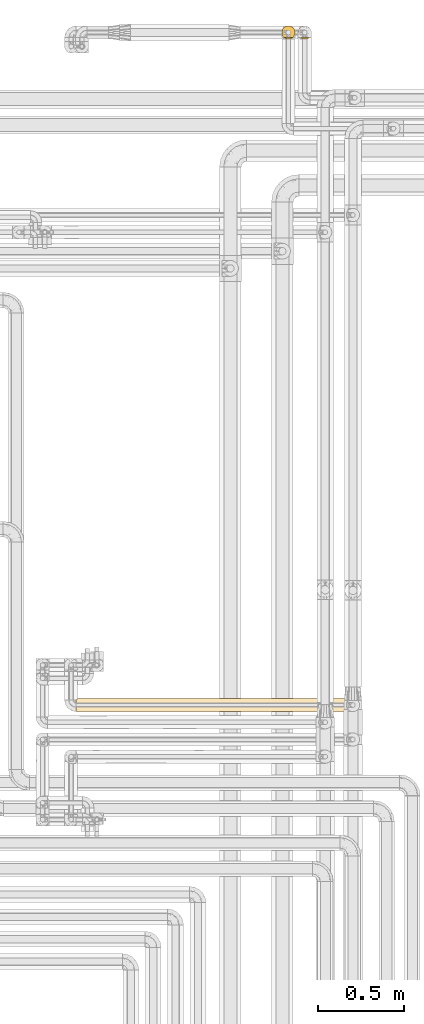
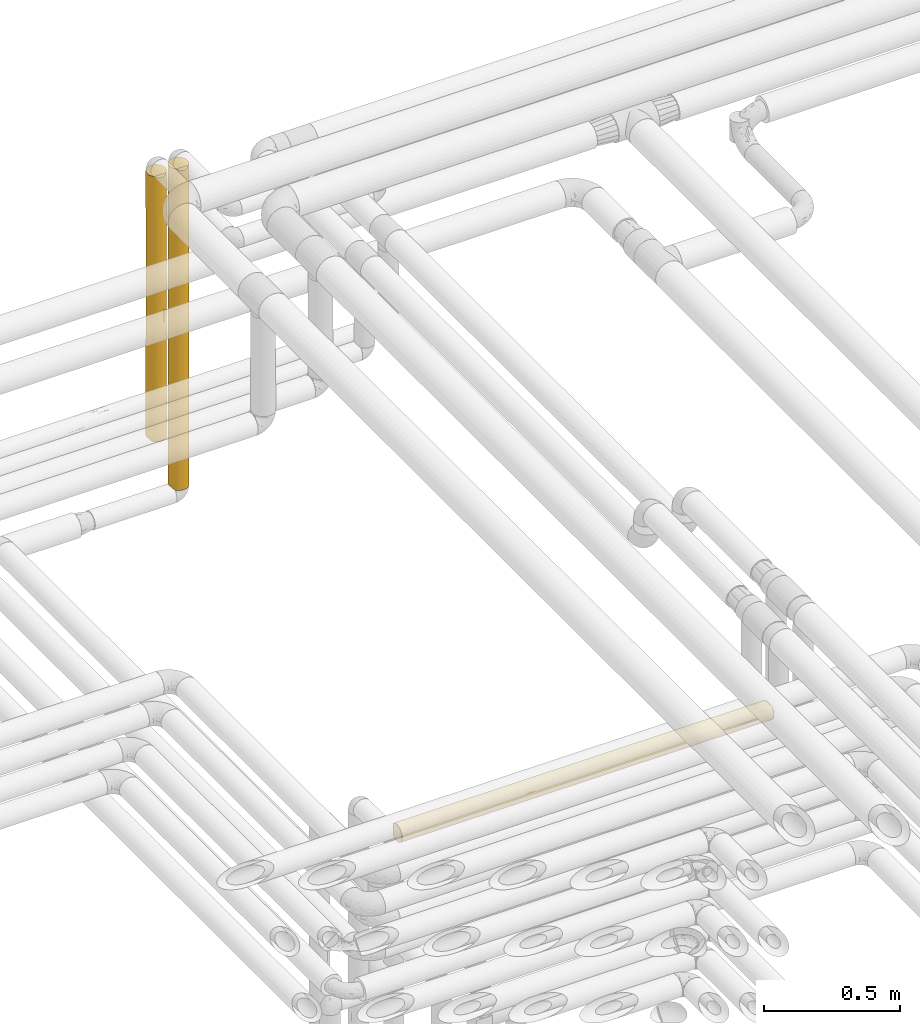
# One storey, part 44 of 827: 3 coverings.
"""IFC2X3 building model written with IfcOpenShell, lengths in millimetres."""

from ifc_helpers import new_model, entity, si_unit, converted_unit, derived_unit, direction, frame, origin, place, context, subcontext, project, spatial, faceted_brep, element, save


model = new_model("IFC2X3")

# Units and contexts
model_context = context("Model", 3, precision=0.01, world=origin(), true_north=direction((6.12303176911189e-17, 1.0)))
body_context = subcontext(model_context, "Body", "Model", "MODEL_VIEW")
ifc_project = project(units=[si_unit("LENGTHUNIT", "METRE", prefix="MILLI"), si_unit("AREAUNIT", "SQUARE_METRE"), si_unit("VOLUMEUNIT", "CUBIC_METRE"), converted_unit("PLANEANGLEUNIT", "DEGREE", entity("IfcRatioMeasure", 0.0174532925199433), si_unit("PLANEANGLEUNIT", "RADIAN"), dimensions=[0, 0, 0, 0, 0, 0, 0]), si_unit("MASSUNIT", "GRAM", prefix="KILO"), derived_unit("MASSDENSITYUNIT", [(si_unit("MASSUNIT", "GRAM", prefix="KILO"), 1), (si_unit("LENGTHUNIT", "METRE"), -3)]), derived_unit("MOMENTOFINERTIAUNIT", [(si_unit("LENGTHUNIT", "METRE"), 4)]), si_unit("TIMEUNIT", "SECOND"), si_unit("FREQUENCYUNIT", "HERTZ"), si_unit("THERMODYNAMICTEMPERATUREUNIT", "DEGREE_CELSIUS"), derived_unit("THERMALTRANSMITTANCEUNIT", [(si_unit("MASSUNIT", "GRAM", prefix="KILO"), 1), (si_unit("THERMODYNAMICTEMPERATUREUNIT", "KELVIN"), -1), (si_unit("TIMEUNIT", "SECOND"), -3)]), derived_unit("VOLUMETRICFLOWRATEUNIT", [(si_unit("LENGTHUNIT", "METRE"), 3), (si_unit("TIMEUNIT", "SECOND"), -1)]), derived_unit("MASSFLOWRATEUNIT", [(si_unit("MASSUNIT", "GRAM", prefix="KILO"), 1), (si_unit("TIMEUNIT", "SECOND"), -1)]), derived_unit("ROTATIONALFREQUENCYUNIT", [(si_unit("TIMEUNIT", "SECOND"), -1)]), si_unit("ELECTRICCURRENTUNIT", "AMPERE"), si_unit("ELECTRICVOLTAGEUNIT", "VOLT"), si_unit("POWERUNIT", "WATT"), si_unit("FORCEUNIT", "NEWTON", prefix="KILO"), si_unit("ILLUMINANCEUNIT", "LUX"), si_unit("LUMINOUSFLUXUNIT", "LUMEN"), si_unit("LUMINOUSINTENSITYUNIT", "CANDELA"), derived_unit("USERDEFINED", [(si_unit("MASSUNIT", "GRAM", prefix="KILO"), -1), (si_unit("LENGTHUNIT", "METRE"), -2), (si_unit("TIMEUNIT", "SECOND"), 3), (si_unit("LUMINOUSFLUXUNIT", "LUMEN"), 1)]), derived_unit("LINEARVELOCITYUNIT", [(si_unit("LENGTHUNIT", "METRE"), 1), (si_unit("TIMEUNIT", "SECOND"), -1)]), si_unit("PRESSUREUNIT", "PASCAL"), derived_unit("USERDEFINED", [(si_unit("LENGTHUNIT", "METRE"), -2), (si_unit("MASSUNIT", "GRAM", prefix="KILO"), 1), (si_unit("TIMEUNIT", "SECOND"), -2)]), derived_unit("LINEARFORCEUNIT", [(si_unit("MASSUNIT", "GRAM", prefix="KILO"), 1), (si_unit("LENGTHUNIT", "METRE"), 1), (si_unit("TIMEUNIT", "SECOND"), -2), (si_unit("LENGTHUNIT", "METRE"), -1)]), derived_unit("PLANARFORCEUNIT", [(si_unit("MASSUNIT", "GRAM", prefix="KILO"), 1), (si_unit("LENGTHUNIT", "METRE"), 1), (si_unit("TIMEUNIT", "SECOND"), -2), (si_unit("LENGTHUNIT", "METRE"), -2)])], contexts=[model_context])

# Site, building, storey
site_placement = place(None, origin())
site = spatial("IfcSite", under=ifc_project, at=site_placement, CompositionType="ELEMENT")
building_placement = place(site_placement, origin())
building = spatial("IfcBuilding", under=site, at=building_placement, CompositionType="ELEMENT")
storey_placement = place(building_placement, frame((0.0, 0.0, 28200.0)))
storey = spatial("IfcBuildingStorey", under=building, at=storey_placement, Name="08", CompositionType="ELEMENT", Elevation=28200.0)

# Coverings
covering_1_placement = place(storey_placement, frame((36310.03, 19454.61, 1727.5)))
element("IfcCovering", 1, at=covering_1_placement, inside=storey, Name=":ADSK_", ObjectType=":ADSK_", PredefinedType="INSULATION", context=body_context, shape_type="Brep", body=[
    faceted_brep([(31.79, 2.48, 1.6), (23.98, 5.09, 1.6), (16.91, 9.31, 1.6), (10.9, 14.94, 1.6), (10.9, 65.05, 1.6), (16.91, 70.68, 1.6), (23.98, 74.9, 1.6), (31.79, 77.51, 1.6), (40.0, 78.4, 1.6), (49.93, 77.09, 1.6), (59.2, 73.25, 1.6), (67.15, 67.15, 1.6), (73.25, 59.2, 1.6), (77.09, 49.93, 1.6), (78.4, 40.0, 1.6), (77.09, 30.06, 1.6), (73.25, 20.8, 1.6), (67.15, 12.84, 1.6), (59.2, 6.74, 1.6), (49.93, 2.9, 1.6), (40.0, 1.6, 1.6), (1.6, 40.0, 1443.4), (2.48, 31.79, 1443.4), (5.09, 23.98, 1443.4), (9.31, 16.91, 1443.4), (14.94, 10.9, 1443.4), (65.05, 10.9, 1443.4), (70.68, 16.91, 1443.4), (74.9, 23.98, 1443.4), (77.51, 31.79, 1443.4), (78.4, 40.0, 1443.4), (77.09, 49.93, 1443.4), (73.25, 59.2, 1443.4), (67.15, 67.15, 1443.4), (59.2, 73.25, 1443.4), (49.93, 77.09, 1443.4), (40.0, 78.4, 1443.4), (30.06, 77.09, 1443.4), (20.8, 73.25, 1443.4), (12.84, 67.15, 1443.4), (6.74, 59.2, 1443.4), (2.9, 49.93, 1443.4), (63.37, 70.46, 1184.2), (61.62, 71.73, 488.77), (70.85, 62.86, 616.54), (70.46, 63.37, 291.04), (40.0, 78.4, 1010.65), (47.28, 77.7, 1118.84), (47.94, 77.56, 820.43), (63.37, 70.46, 255.05), (78.4, 40.0, 217.97), (78.4, 40.0, 1227.02), (53.03, 76.11, 1248.93), (54.69, 75.47, 1039.29), (77.77, 46.88, 881.75), (76.52, 51.85, 674.53), (75.47, 54.69, 913.68), (40.0, 78.4, 217.97), (40.0, 78.4, 289.75), (40.0, 78.4, 1227.02), (77.69, 47.3, 489.51), (77.25, 49.31, 248.84), (75.47, 54.69, 435.38), (75.47, 54.69, 1198.34), (70.46, 63.37, 1119.12), (77.7, 47.28, 1118.84), (74.58, 56.69, 215.37), (47.44, 77.67, 352.93), (52.54, 76.29, 201.5), (55.55, 75.11, 690.22), (48.42, 77.46, 576.01), (40.0, 78.4, 794.28), (71.39, 62.1, 876.16), (66.03, 68.22, 953.35), (60.12, 72.7, 909.2), (40.0, 78.4, 577.9), (54.69, 75.47, 405.7), (63.37, 70.46, 722.5), (78.4, 40.0, 1010.65), (78.4, 40.0, 794.28), (78.4, 40.0, 577.9), (40.0, 78.4, 434.34), (40.0, 78.4, 650.71), (40.0, 78.4, 867.09), (77.14, 30.25, 828.17), (76.41, 27.82, 1157.76), (62.48, 8.86, 1250.93), (59.51, 6.92, 1439.42), (72.98, 20.33, 1226.33), (57.25, 5.69, 841.76), (50.46, 3.05, 756.92), (56.62, 5.38, 623.7), (50.06, 2.94, 225.62), (54.69, 4.52, 399.75), (46.73, 2.19, 426.85), (63.37, 9.53, 255.05), (68.03, 13.75, 1157.75), (67.73, 13.43, 900.85), (72.98, 20.33, 959.81), (75.47, 25.3, 194.3), (77.62, 32.3, 314.84), (75.47, 25.3, 435.38), (77.56, 32.05, 547.37), (63.21, 9.41, 1038.13), (62.77, 9.08, 727.8), (40.0, 1.6, 1217.72), (48.24, 2.49, 1109.54), (46.78, 2.2, 1434.7), (56.68, 5.41, 1060.0), (40.0, 1.6, 568.6), (40.0, 1.6, 285.1), (70.46, 16.62, 291.04), (53.36, 4.0, 1436.5), (62.47, 8.86, 490.45), (56.88, 5.51, 199.52), (40.0, 1.6, 1001.35), (70.72, 16.96, 629.14), (40.0, 1.6, 1434.1), (40.0, 1.6, 784.98), (75.62, 25.67, 656.25), (11.96, 13.75, 1175.61), (20.48, 6.92, 247.08), (27.82, 3.58, 385.09), (3.58, 27.82, 1175.61), (3.13, 29.25, 864.65), (7.01, 20.33, 1004.44), (4.0, 26.63, 8.5), (2.98, 29.79, 312.87), (2.2, 33.21, 10.29), (16.72, 9.45, 1050.04), (17.52, 8.86, 1257.06), (31.75, 2.49, 1109.54), (29.53, 3.05, 756.92), (33.21, 2.2, 1434.7), (26.63, 4.0, 1436.5), (1.6, 40.0, 227.27), (1.6, 40.0, 10.9), (20.66, 6.82, 502.11), (7.01, 20.33, 1240.02), (20.48, 6.92, 1439.42), (2.45, 31.94, 571.46), (5.45, 23.23, 559.71), (12.21, 13.49, 910.45), (10.5, 15.41, 639.65), (17.22, 9.08, 727.8), (1.6, 40.0, 876.39), (13.75, 11.96, 366.6), (6.74, 20.79, 288.27), (6.92, 20.48, 5.57), (1.6, 40.0, 443.64), (23.22, 5.45, 690.32), (6.79, 20.7, 774.58), (23.31, 5.41, 1060.0), (1.6, 40.0, 1227.02), (1.6, 40.0, 1159.89), (1.6, 40.0, 660.01), (16.62, 70.46, 1153.95), (9.53, 63.37, 1189.94), (9.41, 63.21, 406.86), (9.08, 62.77, 717.19), (13.43, 67.73, 544.14), (2.19, 46.73, 1018.14), (2.94, 50.06, 1219.37), (4.52, 54.69, 1045.24), (8.86, 62.48, 194.06), (6.92, 59.51, 5.57), (5.41, 56.68, 384.99), (5.51, 56.88, 1245.47), (4.0, 53.36, 8.5), (25.3, 75.47, 1250.69), (2.49, 48.24, 335.45), (2.2, 46.78, 10.29), (13.75, 68.03, 287.24), (27.82, 76.41, 287.23), (3.05, 50.46, 688.07), (8.86, 62.47, 954.54), (16.96, 70.72, 815.85), (32.3, 77.62, 1130.15), (25.3, 75.47, 1009.61), (32.05, 77.56, 897.62), (20.33, 72.98, 218.66), (20.33, 72.98, 485.18), (30.25, 77.14, 616.82), (5.69, 57.25, 603.23), (5.38, 56.62, 821.29), (25.67, 75.62, 788.74)], [[[0, 1, 2, 3, 4, 5, 6, 7, 8, 9, 10, 11, 12, 13, 14, 15, 16, 17, 18, 19, 20]], [[21, 22, 23, 24, 25, 26, 27, 28, 29, 30, 31, 32, 33, 34, 35, 36, 37, 38, 39, 40, 41]], [[34, 33, 42]], [[43, 44, 45]], [[46, 47, 48]], [[11, 49, 45]], [[14, 13, 50]], [[31, 30, 51]], [[47, 52, 53]], [[54, 55, 56]], [[9, 8, 57, 58]], [[59, 36, 35]], [[60, 61, 62]], [[35, 52, 47]], [[32, 31, 63]], [[42, 33, 64]], [[63, 65, 56]], [[63, 64, 32]], [[32, 64, 33]], [[66, 62, 61]], [[12, 11, 45]], [[67, 68, 9]], [[48, 53, 69]], [[45, 62, 66]], [[62, 45, 44]], [[70, 71, 48]], [[35, 47, 59]], [[64, 72, 73]], [[58, 67, 9]], [[56, 65, 54]], [[74, 42, 73]], [[11, 10, 49]], [[60, 62, 55]], [[49, 43, 45]], [[73, 42, 64]], [[67, 75, 70]], [[52, 42, 53]], [[68, 49, 10]], [[43, 49, 76]], [[77, 73, 72]], [[44, 72, 55]], [[51, 65, 31]], [[64, 63, 56]], [[65, 51, 78]], [[65, 78, 54]], [[31, 65, 63]], [[55, 79, 80]], [[80, 60, 55]], [[54, 79, 55]], [[44, 55, 62]], [[54, 78, 79]], [[59, 47, 46]], [[48, 47, 53]], [[53, 74, 69]], [[48, 69, 70]], [[35, 34, 52]], [[42, 52, 34]], [[80, 50, 60]], [[61, 50, 13]], [[50, 61, 60]], [[66, 13, 12]], [[13, 66, 61]], [[45, 66, 12]], [[64, 56, 72]], [[74, 73, 77]], [[55, 72, 56]], [[77, 72, 44]], [[74, 77, 69]], [[42, 74, 53]], [[43, 69, 77]], [[69, 76, 70]], [[67, 70, 76]], [[67, 76, 68]], [[67, 58, 81, 75]], [[49, 68, 76]], [[10, 9, 68]], [[69, 43, 76]], [[44, 43, 77]], [[70, 75, 82, 71]], [[48, 71, 83, 46]], [[84, 78, 85]], [[86, 26, 87]], [[88, 28, 27]], [[89, 90, 91]], [[92, 93, 94]], [[18, 17, 95]], [[85, 51, 29]], [[27, 96, 88]], [[96, 97, 98]], [[99, 16, 15]], [[100, 101, 99]], [[80, 102, 100]], [[88, 98, 85]], [[103, 104, 97]], [[105, 106, 107]], [[90, 108, 106]], [[94, 109, 110]], [[26, 96, 27]], [[99, 111, 16]], [[86, 112, 108]], [[28, 85, 29]], [[103, 86, 108]], [[113, 93, 95]], [[92, 114, 93]], [[111, 95, 17]], [[112, 107, 106]], [[101, 100, 102]], [[105, 115, 106]], [[104, 113, 116]], [[16, 111, 17]], [[84, 85, 98]], [[29, 51, 30]], [[107, 117, 105]], [[90, 115, 118, 109]], [[106, 108, 112]], [[94, 90, 109]], [[90, 94, 91]], [[15, 14, 50]], [[116, 111, 101]], [[104, 91, 113]], [[98, 116, 119]], [[102, 79, 84]], [[119, 101, 102]], [[19, 92, 20]], [[97, 116, 98]], [[111, 116, 113]], [[78, 51, 85]], [[114, 95, 93]], [[110, 20, 92]], [[94, 93, 91]], [[110, 92, 94]], [[114, 19, 18]], [[19, 114, 92]], [[95, 114, 18]], [[100, 15, 50]], [[111, 99, 101]], [[15, 100, 99]], [[80, 100, 50]], [[119, 102, 84]], [[98, 119, 84]], [[116, 101, 119]], [[103, 97, 96]], [[116, 97, 104]], [[96, 26, 86]], [[103, 108, 89]], [[86, 87, 112]], [[96, 86, 103]], [[98, 88, 96]], [[28, 88, 85]], [[115, 90, 106]], [[89, 91, 104]], [[93, 113, 91]], [[113, 95, 111]], [[103, 89, 104]], [[90, 89, 108]], [[79, 102, 80]], [[79, 78, 84]], [[120, 25, 24]], [[121, 1, 122]], [[123, 124, 125]], [[126, 127, 128]], [[129, 130, 120]], [[131, 132, 115]], [[133, 134, 131]], [[135, 136, 128]], [[1, 121, 2]], [[0, 110, 122]], [[135, 128, 127]], [[22, 123, 23]], [[137, 121, 122]], [[125, 138, 123]], [[139, 130, 134]], [[140, 127, 141]], [[142, 120, 125]], [[142, 143, 144]], [[123, 145, 124]], [[115, 132, 109, 118]], [[146, 121, 137]], [[147, 126, 148]], [[129, 120, 142]], [[147, 127, 126]], [[24, 23, 138]], [[138, 120, 24]], [[147, 3, 146]], [[149, 127, 140]], [[3, 2, 146]], [[137, 150, 144]], [[105, 117, 133]], [[1, 0, 122]], [[147, 141, 127]], [[142, 125, 151]], [[131, 134, 152]], [[115, 105, 131]], [[22, 21, 153]], [[130, 139, 25]], [[22, 153, 123]], [[123, 153, 154, 145]], [[133, 131, 105]], [[131, 152, 132]], [[150, 152, 144]], [[122, 109, 132]], [[124, 155, 140]], [[151, 124, 141]], [[123, 138, 23]], [[120, 138, 125]], [[143, 151, 141]], [[129, 144, 152]], [[147, 143, 141]], [[146, 144, 143]], [[3, 147, 148]], [[143, 147, 146]], [[144, 129, 142]], [[152, 134, 130]], [[120, 130, 25]], [[152, 130, 129]], [[141, 124, 140]], [[110, 0, 20]], [[142, 151, 143]], [[124, 151, 125]], [[155, 124, 145]], [[155, 149, 140]], [[110, 109, 122]], [[2, 121, 146]], [[150, 122, 132]], [[146, 137, 144]], [[122, 150, 137]], [[152, 150, 132]], [[127, 149, 135]], [[39, 156, 157]], [[158, 159, 160]], [[161, 145, 154]], [[162, 163, 161]], [[164, 4, 165]], [[164, 166, 158]], [[162, 167, 163]], [[168, 166, 164]], [[169, 156, 38]], [[135, 170, 171]], [[40, 39, 157]], [[4, 172, 5]], [[170, 135, 149]], [[173, 57, 7]], [[174, 166, 170]], [[159, 175, 176]], [[177, 178, 169]], [[175, 163, 157]], [[178, 177, 179]], [[172, 180, 5]], [[172, 160, 181]], [[180, 6, 5]], [[6, 173, 7]], [[37, 169, 38]], [[182, 81, 173]], [[38, 156, 39]], [[168, 171, 170]], [[181, 173, 180]], [[183, 174, 184]], [[83, 179, 177]], [[182, 173, 181]], [[7, 57, 8]], [[171, 136, 135]], [[174, 149, 155, 145]], [[170, 166, 168]], [[161, 174, 145]], [[174, 161, 184]], [[37, 36, 59]], [[176, 156, 178]], [[159, 184, 175]], [[181, 176, 185]], [[179, 82, 182]], [[185, 178, 179]], [[41, 162, 21]], [[160, 176, 181]], [[156, 176, 175]], [[173, 81, 58, 57]], [[167, 157, 163]], [[162, 154, 153, 21]], [[161, 163, 184]], [[154, 162, 161]], [[167, 41, 40]], [[41, 167, 162]], [[157, 167, 40]], [[177, 37, 59]], [[156, 169, 178]], [[37, 177, 169]], [[177, 59, 46, 83]], [[185, 179, 182]], [[181, 185, 182]], [[176, 178, 185]], [[158, 160, 172]], [[176, 160, 159]], [[172, 4, 164]], [[158, 166, 183]], [[164, 165, 168]], [[172, 164, 158]], [[181, 180, 172]], [[6, 180, 173]], [[149, 174, 170]], [[183, 184, 159]], [[163, 175, 184]], [[175, 157, 156]], [[158, 183, 159]], [[174, 183, 166]], [[179, 83, 71, 82]], [[182, 82, 75, 81]], [[128, 136, 171, 168, 165, 4, 3, 148, 126]], [[139, 134, 133, 117, 107, 112, 87, 26, 25]]]),
])
covering_2_placement = place(storey_placement, frame((36215.03, 19454.61, 1977.5)))
element("IfcCovering", 2, at=covering_2_placement, inside=storey, Name=":ADSK_", ObjectType=":ADSK_", PredefinedType="INSULATION", context=body_context, shape_type="Brep", body=[
    faceted_brep([(16.91, 9.31, 1.6), (10.9, 14.94, 1.6), (10.9, 65.05, 1.6), (16.91, 70.68, 1.6), (23.98, 74.9, 1.6), (31.79, 77.51, 1.6), (40.0, 78.4, 1.6), (49.93, 77.09, 1.6), (59.2, 73.25, 1.6), (67.15, 67.15, 1.6), (73.25, 59.2, 1.6), (77.09, 49.93, 1.6), (78.4, 40.0, 1.6), (77.09, 30.06, 1.6), (73.25, 20.8, 1.6), (67.15, 12.84, 1.6), (59.2, 6.74, 1.6), (49.93, 2.9, 1.6), (40.0, 1.6, 1.6), (31.79, 2.48, 1.6), (23.98, 5.09, 1.6), (6.74, 59.2, 1193.4), (2.9, 49.93, 1193.4), (1.6, 40.0, 1193.4), (2.48, 31.79, 1193.4), (5.09, 23.98, 1193.4), (9.31, 16.91, 1193.4), (14.94, 10.9, 1193.4), (65.05, 10.9, 1193.4), (70.68, 16.91, 1193.4), (74.9, 23.98, 1193.4), (77.51, 31.79, 1193.4), (78.4, 40.0, 1193.4), (77.09, 49.93, 1193.4), (73.25, 59.2, 1193.4), (67.15, 67.15, 1193.4), (59.2, 73.25, 1193.4), (49.93, 77.09, 1193.4), (40.0, 78.4, 1193.4), (30.06, 77.09, 1193.4), (20.8, 73.25, 1193.4), (12.84, 67.15, 1193.4), (54.69, 75.47, 842.63), (63.37, 70.46, 928.29), (47.05, 77.74, 868.84), (40.0, 78.4, 977.02), (70.46, 63.37, 842.63), (54.69, 75.47, 352.36), (48.79, 77.37, 597.5), (56.45, 74.69, 614.43), (63.37, 70.46, 257.99), (63.37, 70.46, 597.5), (70.46, 63.37, 310.86), (77.68, 47.38, 448.49), (78.4, 40.0, 381.12), (77.83, 46.53, 225.32), (40.0, 78.4, 217.97), (75.47, 54.69, 928.29), (77.2, 49.52, 709.99), (75.47, 54.69, 491.69), (40.0, 78.4, 434.34), (40.0, 78.4, 760.65), (75.47, 54.69, 225.24), (70.17, 63.75, 576.75), (74.43, 57.0, 709.99), (47.05, 77.74, 326.15), (77.68, 47.37, 921.52), (78.4, 40.0, 760.65), (78.4, 40.0, 217.97), (78.4, 40.0, 434.34), (78.4, 40.0, 977.02), (72.98, 20.33, 983.31), (76.41, 27.82, 920.69), (59.51, 6.92, 1189.42), (62.37, 8.79, 985.18), (75.47, 25.3, 374.94), (52.63, 3.73, 613.29), (62.71, 9.03, 594.48), (56.65, 5.4, 864.37), (40.0, 1.6, 217.97), (68.03, 13.75, 920.68), (77.73, 32.87, 326.15), (70.46, 16.62, 272.57), (72.98, 20.33, 741.91), (76.69, 28.68, 638.63), (64.05, 10.06, 791.52), (68.61, 14.39, 642.2), (53.36, 4.0, 1186.5), (48.14, 2.47, 859.54), (63.37, 9.53, 253.23), (47.04, 2.25, 326.15), (54.69, 4.52, 339.92), (40.0, 1.6, 967.72), (40.0, 1.6, 751.35), (40.0, 1.6, 434.34), (46.78, 2.2, 1184.7), (40.0, 1.6, 1184.1), (66.77, 12.47, 433.77), (23.4, 5.36, 996.33), (20.48, 6.92, 1189.42), (17.46, 8.9, 915.02), (4.0, 26.63, 8.5), (6.92, 20.48, 5.57), (5.39, 23.34, 327.84), (27.82, 3.58, 348.98), (20.23, 7.07, 452.71), (20.33, 7.01, 211.5), (9.06, 17.24, 382.0), (9.03, 17.29, 594.44), (3.58, 27.82, 846.01), (3.76, 27.28, 572.61), (23.26, 5.43, 695.68), (29.8, 2.97, 909.09), (33.21, 2.2, 1184.7), (26.63, 4.0, 1186.5), (31.67, 2.51, 654.72), (13.75, 11.96, 321.64), (1.6, 40.0, 227.27), (1.6, 40.0, 10.9), (2.2, 33.21, 10.29), (1.6, 40.0, 443.64), (2.47, 31.85, 335.45), (15.39, 10.52, 651.39), (1.6, 40.0, 760.65), (1.6, 40.0, 977.02), (8.16, 18.52, 895.06), (12.49, 13.2, 826.87), (4.52, 54.69, 855.07), (3.73, 52.63, 581.71), (9.03, 62.71, 600.51), (5.4, 56.65, 330.62), (2.47, 48.14, 335.45), (13.75, 68.03, 274.31), (14.39, 68.61, 552.79), (20.33, 72.98, 453.08), (25.3, 75.47, 820.05), (32.87, 77.73, 868.84), (30.78, 77.27, 600.01), (4.0, 53.36, 8.5), (6.92, 59.51, 5.57), (2.25, 47.04, 868.84), (16.62, 70.46, 922.42), (8.79, 62.37, 209.81), (10.06, 64.05, 403.47), (9.53, 63.37, 941.76), (2.2, 46.78, 10.29), (29.67, 76.98, 326.15), (20.33, 72.98, 211.68), (12.47, 66.77, 761.22)], [[[0, 1, 2, 3, 4, 5, 6, 7, 8, 9, 10, 11, 12, 13, 14, 15, 16, 17, 18, 19, 20]], [[21, 22, 23, 24, 25, 26, 27, 28, 29, 30, 31, 32, 33, 34, 35, 36, 37, 38, 39, 40, 41]], [[42, 36, 43]], [[37, 44, 45]], [[43, 36, 35]], [[36, 42, 37]], [[35, 34, 46]], [[44, 37, 42]], [[47, 48, 49]], [[50, 51, 52]], [[51, 43, 46]], [[53, 54, 55]], [[7, 6, 56]], [[45, 38, 37]], [[46, 34, 57]], [[43, 51, 49]], [[58, 53, 59]], [[52, 10, 9]], [[48, 60, 61]], [[11, 10, 62]], [[50, 52, 9]], [[47, 8, 7]], [[59, 63, 64]], [[52, 59, 62]], [[55, 11, 62]], [[57, 34, 33]], [[65, 56, 60]], [[66, 67, 58]], [[9, 8, 50]], [[61, 44, 48]], [[11, 55, 12]], [[64, 63, 46]], [[35, 46, 43]], [[66, 58, 57]], [[64, 57, 58]], [[8, 47, 50]], [[51, 50, 47]], [[49, 48, 42]], [[48, 65, 60]], [[52, 62, 10]], [[53, 55, 62]], [[53, 62, 59]], [[55, 54, 68, 12]], [[59, 64, 58]], [[53, 67, 69, 54]], [[66, 33, 32]], [[67, 53, 58]], [[32, 70, 67, 66]], [[45, 44, 61]], [[48, 44, 42]], [[65, 48, 47]], [[56, 65, 7]], [[7, 65, 47]], [[63, 59, 52]], [[46, 57, 64]], [[52, 51, 63]], [[51, 46, 63]], [[33, 66, 57]], [[43, 49, 42]], [[47, 49, 51]], [[71, 72, 30]], [[28, 73, 74]], [[75, 14, 13]], [[76, 77, 78]], [[17, 79, 18]], [[80, 29, 28]], [[29, 71, 30]], [[31, 72, 70]], [[30, 72, 31]], [[13, 68, 81]], [[15, 14, 82]], [[72, 83, 84]], [[71, 80, 83]], [[80, 85, 86]], [[78, 73, 87]], [[14, 75, 82]], [[76, 78, 88]], [[16, 15, 89]], [[90, 17, 91]], [[92, 93, 88]], [[76, 94, 90]], [[91, 17, 16]], [[83, 80, 86]], [[92, 88, 95]], [[80, 74, 85]], [[82, 89, 15]], [[81, 68, 54, 69]], [[74, 73, 78]], [[84, 69, 67]], [[87, 95, 88]], [[84, 83, 75]], [[84, 67, 72]], [[95, 96, 92]], [[93, 94, 76]], [[88, 78, 87]], [[76, 88, 93]], [[77, 76, 91]], [[86, 75, 83]], [[89, 77, 91]], [[80, 71, 29]], [[72, 71, 83]], [[97, 86, 77]], [[91, 16, 89]], [[84, 75, 81]], [[32, 31, 70]], [[17, 90, 79]], [[94, 79, 90]], [[76, 90, 91]], [[13, 12, 68]], [[84, 81, 69]], [[13, 81, 75]], [[85, 78, 77]], [[28, 74, 80]], [[78, 85, 74]], [[85, 77, 86]], [[97, 77, 89]], [[75, 86, 82]], [[89, 82, 97]], [[82, 86, 97]], [[72, 67, 70]], [[98, 99, 100]], [[101, 102, 103]], [[104, 105, 106]], [[107, 108, 103]], [[109, 110, 108]], [[111, 112, 98]], [[112, 113, 114]], [[112, 111, 115]], [[1, 0, 116]], [[115, 93, 112]], [[117, 118, 119]], [[92, 112, 93]], [[120, 121, 110]], [[114, 98, 112]], [[19, 79, 104]], [[122, 111, 100]], [[100, 99, 27]], [[104, 111, 105]], [[123, 109, 124]], [[125, 109, 108]], [[115, 94, 93]], [[119, 101, 121]], [[24, 109, 25]], [[107, 1, 116]], [[92, 96, 113]], [[119, 121, 117]], [[25, 109, 125]], [[24, 124, 109]], [[1, 107, 102]], [[104, 20, 19]], [[94, 104, 79]], [[27, 26, 126]], [[126, 26, 125]], [[120, 110, 123]], [[92, 113, 112]], [[106, 0, 20]], [[105, 111, 122]], [[121, 101, 103]], [[120, 117, 121]], [[110, 121, 103]], [[108, 110, 103]], [[123, 110, 109]], [[24, 23, 124]], [[19, 18, 79]], [[126, 122, 100]], [[116, 122, 108]], [[122, 116, 105]], [[116, 0, 106]], [[104, 106, 20]], [[116, 106, 105]], [[111, 104, 115]], [[94, 115, 104]], [[108, 122, 126]], [[25, 125, 26]], [[99, 98, 114]], [[111, 98, 100]], [[107, 103, 102]], [[116, 108, 107]], [[27, 126, 100]], [[108, 126, 125]], [[127, 22, 21]], [[128, 129, 130]], [[130, 131, 128]], [[132, 133, 134]], [[135, 136, 137]], [[138, 130, 139]], [[140, 22, 127]], [[120, 131, 117]], [[40, 135, 141]], [[142, 143, 132]], [[21, 41, 144]], [[117, 131, 145]], [[139, 130, 142]], [[132, 3, 2]], [[137, 60, 146]], [[141, 144, 41]], [[61, 136, 45]], [[56, 146, 60]], [[4, 146, 5]], [[41, 40, 141]], [[56, 6, 5]], [[135, 40, 39]], [[128, 123, 140]], [[3, 147, 4]], [[39, 45, 136]], [[138, 145, 131]], [[4, 147, 146]], [[134, 147, 132]], [[134, 135, 137]], [[56, 5, 146]], [[22, 124, 23]], [[2, 139, 142]], [[132, 143, 133]], [[145, 118, 117]], [[120, 123, 128]], [[131, 130, 138]], [[128, 131, 120]], [[129, 128, 127]], [[133, 135, 134]], [[144, 129, 127]], [[132, 147, 3]], [[146, 147, 134]], [[148, 133, 129]], [[127, 21, 144]], [[22, 140, 124]], [[123, 124, 140]], [[128, 140, 127]], [[39, 38, 45]], [[61, 60, 137]], [[39, 136, 135]], [[137, 136, 61]], [[134, 137, 146]], [[143, 130, 129]], [[2, 142, 132]], [[130, 143, 142]], [[143, 129, 133]], [[148, 129, 144]], [[135, 133, 141]], [[144, 141, 148]], [[141, 133, 148]], [[119, 118, 145, 138, 139, 2, 1, 102, 101]], [[99, 114, 113, 96, 95, 87, 73, 28, 27]]]),
])
covering_3_placement = place(storey_placement, frame((35020.39, 15550.04, 2960.0)))
element("IfcCovering", 3, at=covering_3_placement, inside=storey, Name=":ADSK_", ObjectType=":ADSK_", PredefinedType="INSULATION", context=body_context, shape_type="Brep", body=[
    faceted_brep([(1580.15, 59.2, 6.74), (1580.15, 67.15, 12.84), (1580.15, 73.25, 20.8), (1580.15, 77.09, 30.06), (1580.15, 78.4, 40.0), (1580.15, 77.51, 48.2), (1580.15, 74.9, 56.01), (1580.15, 70.68, 63.08), (1580.15, 65.05, 69.1), (1580.15, 14.94, 69.1), (1580.15, 9.31, 63.08), (1580.15, 5.09, 56.01), (1580.15, 2.48, 48.2), (1580.15, 1.6, 40.0), (1580.15, 2.9, 30.06), (1580.15, 6.74, 20.8), (1580.15, 12.84, 12.84), (1580.15, 20.8, 6.74), (1580.15, 30.06, 2.9), (1580.15, 40.0, 1.6), (1580.15, 49.93, 2.9), (1.6, 69.1, 14.94), (1.6, 63.08, 9.31), (1.6, 56.01, 5.09), (1.6, 48.2, 2.48), (1.6, 40.0, 1.6), (1.6, 30.06, 2.9), (1.6, 20.8, 6.74), (1.6, 12.84, 12.84), (1.6, 6.74, 20.8), (1.6, 2.9, 30.06), (1.6, 1.6, 40.0), (1.6, 2.9, 49.93), (1.6, 6.74, 59.2), (1.6, 12.84, 67.15), (1.6, 20.8, 73.25), (1.6, 30.06, 77.09), (1.6, 40.0, 78.4), (1.6, 48.2, 77.51), (1.6, 56.01, 74.9), (1.6, 63.08, 70.68), (1.6, 69.1, 65.05), (325.87, 16.62, 9.53), (1097.61, 12.03, 13.68), (1276.67, 16.62, 9.53), (1324.71, 9.53, 16.62), (260.79, 9.53, 16.62), (326.15, 2.41, 32.13), (221.65, 4.83, 24.57), (472.28, 4.52, 25.3), (1365.16, 25.3, 4.52), (1235.54, 31.85, 2.47), (575.37, 2.26, 32.87), (434.34, 1.6, 40.0), (776.53, 4.52, 25.29), (1332.54, 2.42, 32.07), (1363.78, 1.6, 40.0), (1223.62, 1.6, 40.0), (1223.62, 40.0, 1.6), (1008.59, 32.09, 2.42), (563.24, 33.12, 2.22), (818.62, 27.93, 3.54), (531.31, 25.3, 4.52), (246.65, 25.3, 4.52), (326.15, 32.71, 2.29), (565.66, 11.38, 14.38), (1404.29, 4.61, 25.07), (798.65, 2.3, 32.66), (802.43, 18.29, 8.32), (870.52, 9.53, 16.62), (1105.92, 25.3, 4.52), (1079.22, 2.25, 32.92), (563.6, 17.57, 8.82), (217.97, 40.0, 1.6), (217.97, 1.6, 40.0), (1042.79, 18.18, 8.4), (1180.99, 4.52, 25.3), (978.76, 4.53, 25.28), (1062.78, 7.45, 19.62), (434.34, 40.0, 1.6), (650.71, 40.0, 1.6), (867.09, 40.0, 1.6), (1363.78, 40.0, 1.6), (1147.41, 40.0, 1.6), (650.71, 1.6, 40.0), (1147.4, 1.6, 40.0), (931.03, 1.6, 40.0), (867.09, 1.6, 40.0), (714.67, 1.6, 40.0), (616.82, 49.74, 2.85), (287.23, 52.17, 3.58), (1007.25, 52.11, 3.56), (1255.59, 47.13, 2.26), (218.66, 59.66, 7.01), (711.85, 74.49, 23.12), (922.22, 76.92, 29.45), (905.74, 73.75, 21.69), (1372.42, 75.47, 25.3), (1361.21, 77.79, 33.19), (287.24, 66.24, 11.96), (544.14, 66.56, 12.26), (485.18, 59.66, 7.01), (830.2, 47.57, 2.35), (779.61, 54.81, 4.57), (227.27, 78.4, 40.0), (335.45, 77.5, 31.75), (10.29, 77.79, 33.21), (688.07, 76.94, 29.53), (384.99, 74.58, 23.31), (1133.63, 77.72, 32.85), (1228.27, 78.4, 40.0), (1364.49, 63.37, 9.53), (194.06, 71.13, 17.51), (8.5, 76.0, 26.63), (406.86, 70.58, 16.78), (1281.39, 70.46, 16.62), (1119.17, 75.47, 25.3), (1306.51, 54.69, 4.52), (443.64, 78.4, 40.0), (954.97, 68.71, 14.5), (794.43, 61.62, 8.26), (717.19, 70.91, 17.22), (1104.69, 63.37, 9.53), (5.57, 73.07, 20.48), (10.9, 78.4, 40.0), (876.39, 78.4, 40.0), (660.01, 78.4, 40.0), (335.45, 77.5, 48.24), (688.07, 76.94, 50.46), (1320.03, 72.98, 59.66), (1161.14, 68.03, 66.24), (1386.09, 68.15, 66.11), (731.87, 56.27, 74.78), (569.85, 49.09, 77.3), (860.06, 48.47, 77.45), (544.14, 66.56, 67.73), (406.86, 70.58, 63.21), (287.24, 66.24, 68.03), (194.06, 71.13, 62.48), (218.66, 59.66, 72.98), (10.29, 77.79, 46.78), (8.5, 76.0, 53.36), (1070.82, 47.04, 77.74), (1001.77, 56.77, 74.54), (1327.31, 62.51, 71.1), (1354.48, 40.0, 78.4), (1571.46, 46.78, 77.79), (1264.27, 50.2, 77.01), (287.23, 52.17, 76.41), (1147.71, 76.41, 52.17), (1380.27, 76.41, 52.17), (1107.71, 62.49, 71.12), (1216.49, 56.99, 74.43), (1576.18, 59.51, 73.07), (384.99, 74.58, 56.68), (986.97, 77.78, 46.82), (908.99, 75.79, 53.91), (1066.37, 72.93, 59.73), (5.57, 73.07, 59.51), (1573.25, 53.36, 76.0), (1570.85, 40.0, 78.4), (850.86, 64.43, 69.62), (485.18, 59.66, 72.98), (217.97, 40.0, 78.4), (353.48, 40.0, 78.4), (434.34, 40.0, 78.4), (705.36, 40.0, 78.4), (717.19, 70.91, 62.77), (730.06, 74.51, 56.82), (921.73, 40.0, 78.4), (1138.11, 40.0, 78.4), (300.36, 16.62, 70.46), (326.15, 2.26, 47.13), (448.12, 32.85, 77.72), (220.54, 33.19, 77.79), (209.33, 25.3, 75.47), (574.5, 3.56, 52.11), (1387.69, 17.51, 71.13), (1196.76, 23.31, 74.58), (1174.89, 16.78, 70.58), (462.58, 25.3, 75.47), (1573.25, 26.63, 76.0), (217.26, 9.53, 63.37), (1246.29, 31.75, 77.5), (1571.46, 33.21, 77.79), (1294.51, 11.96, 66.24), (1294.52, 3.58, 52.17), (893.68, 29.53, 76.94), (626.78, 14.5, 68.71), (787.32, 8.26, 61.62), (864.56, 17.22, 70.91), (802.14, 4.57, 54.81), (751.54, 2.35, 47.57), (964.93, 2.85, 49.74), (275.24, 4.52, 54.69), (1363.09, 7.01, 59.66), (1037.61, 12.26, 66.56), (1096.57, 7.01, 59.66), (477.06, 9.53, 63.37), (869.9, 23.12, 74.49), (659.53, 29.45, 76.92), (676.01, 21.69, 73.75), (1576.18, 20.48, 73.07)], [[[0, 1, 2, 3, 4, 5, 6, 7, 8, 9, 10, 11, 12, 13, 14, 15, 16, 17, 18, 19, 20]], [[21, 22, 23, 24, 25, 26, 27, 28, 29, 30, 31, 32, 33, 34, 35, 36, 37, 38, 39, 40, 41]], [[28, 27, 42]], [[43, 44, 45]], [[46, 28, 42]], [[47, 48, 49]], [[18, 50, 51]], [[52, 53, 47]], [[49, 54, 52]], [[55, 13, 56, 57]], [[58, 51, 59]], [[60, 61, 62]], [[27, 26, 63]], [[17, 16, 44]], [[63, 64, 62]], [[63, 42, 27]], [[46, 65, 49]], [[18, 17, 50]], [[44, 16, 45]], [[55, 66, 14]], [[67, 52, 54]], [[68, 69, 65]], [[44, 70, 50]], [[42, 63, 62]], [[57, 71, 55]], [[65, 42, 72]], [[26, 25, 73]], [[62, 64, 60]], [[74, 30, 47]], [[28, 46, 29]], [[16, 15, 45]], [[18, 51, 19]], [[43, 68, 75]], [[65, 46, 42]], [[47, 49, 52]], [[76, 71, 77]], [[48, 46, 49]], [[65, 72, 68]], [[65, 69, 54]], [[61, 68, 62]], [[43, 75, 44]], [[66, 45, 15]], [[43, 78, 69]], [[73, 64, 26]], [[64, 73, 79]], [[64, 79, 60]], [[26, 64, 63]], [[61, 80, 81]], [[51, 70, 59]], [[60, 80, 61]], [[61, 70, 75]], [[60, 79, 80]], [[44, 50, 17]], [[51, 50, 70]], [[70, 61, 59]], [[51, 58, 82, 19]], [[61, 81, 59]], [[59, 81, 83, 58]], [[47, 53, 74]], [[74, 31, 30]], [[48, 30, 29]], [[65, 54, 49]], [[67, 84, 52]], [[77, 69, 78]], [[71, 67, 77]], [[30, 48, 47]], [[46, 48, 29]], [[78, 45, 76]], [[68, 43, 69]], [[61, 75, 68]], [[70, 44, 75]], [[45, 78, 43]], [[84, 53, 52]], [[77, 78, 76]], [[55, 71, 76]], [[69, 77, 54]], [[71, 57, 85, 86, 87]], [[71, 87, 67]], [[66, 55, 76]], [[13, 55, 14]], [[45, 66, 76]], [[14, 66, 15]], [[42, 62, 72]], [[62, 68, 72]], [[67, 54, 77]], [[67, 87, 88, 84]], [[89, 79, 90]], [[91, 92, 83]], [[93, 23, 22]], [[94, 95, 96]], [[3, 97, 98]], [[97, 3, 2]], [[90, 73, 24]], [[22, 99, 93]], [[99, 100, 101]], [[91, 102, 103]], [[83, 81, 80, 102]], [[93, 101, 90]], [[92, 82, 58, 83]], [[104, 105, 106]], [[105, 107, 108]], [[109, 110, 98]], [[21, 99, 22]], [[1, 0, 111]], [[112, 113, 108]], [[23, 90, 24]], [[114, 112, 108]], [[103, 102, 89]], [[115, 116, 97]], [[115, 2, 1]], [[113, 106, 105]], [[20, 117, 0]], [[104, 118, 105]], [[119, 120, 121]], [[122, 119, 115]], [[111, 117, 122]], [[112, 21, 123]], [[114, 121, 100]], [[89, 90, 101]], [[24, 73, 25]], [[106, 124, 104]], [[125, 95, 107]], [[105, 108, 113]], [[125, 109, 95]], [[108, 107, 94]], [[111, 115, 1]], [[96, 119, 121]], [[101, 120, 103]], [[3, 98, 4]], [[102, 80, 89]], [[82, 92, 20]], [[122, 117, 91]], [[117, 111, 0]], [[79, 73, 90]], [[115, 111, 122]], [[20, 19, 82]], [[91, 117, 92]], [[20, 92, 117]], [[115, 97, 2]], [[109, 98, 97]], [[109, 97, 116]], [[4, 98, 110]], [[95, 109, 116]], [[125, 110, 109]], [[96, 95, 116]], [[107, 118, 126, 125]], [[115, 96, 116]], [[94, 96, 121]], [[115, 119, 96]], [[120, 119, 122]], [[91, 120, 122]], [[120, 101, 100]], [[114, 100, 99]], [[120, 100, 121]], [[99, 21, 112]], [[114, 108, 94]], [[112, 123, 113]], [[99, 112, 114]], [[94, 121, 114]], [[95, 94, 107]], [[101, 93, 99]], [[23, 93, 90]], [[118, 107, 105]], [[83, 102, 91]], [[101, 103, 89]], [[91, 103, 120]], [[80, 79, 89]], [[118, 127, 128]], [[129, 130, 131]], [[132, 133, 134]], [[135, 136, 137]], [[136, 138, 137]], [[40, 139, 137]], [[140, 141, 127]], [[142, 143, 134]], [[144, 131, 130]], [[5, 4, 110]], [[145, 146, 147]], [[38, 148, 39]], [[110, 149, 150]], [[130, 151, 144]], [[5, 150, 6]], [[152, 153, 144]], [[127, 141, 154]], [[7, 6, 129]], [[110, 150, 5]], [[155, 128, 156]], [[157, 130, 129]], [[139, 39, 148]], [[7, 131, 8]], [[158, 138, 141]], [[137, 41, 40]], [[152, 159, 153]], [[145, 160, 146]], [[134, 143, 132]], [[159, 147, 146]], [[125, 128, 155]], [[104, 124, 140]], [[153, 8, 144]], [[130, 157, 161]], [[162, 132, 161]], [[137, 139, 162]], [[148, 163, 164, 165]], [[118, 104, 127]], [[151, 143, 152]], [[135, 137, 162]], [[138, 158, 41]], [[148, 38, 163]], [[133, 165, 166]], [[150, 129, 6]], [[155, 110, 125]], [[157, 129, 149]], [[140, 127, 104]], [[127, 154, 128]], [[167, 168, 154]], [[157, 156, 168]], [[133, 166, 134]], [[162, 148, 133]], [[38, 37, 163]], [[165, 133, 148]], [[129, 150, 149]], [[134, 166, 169]], [[147, 142, 170]], [[161, 132, 143]], [[133, 132, 162]], [[161, 143, 151]], [[161, 167, 135]], [[156, 157, 149]], [[161, 157, 167]], [[155, 156, 149]], [[168, 156, 128]], [[110, 155, 149]], [[118, 128, 125, 126]], [[8, 131, 144]], [[129, 131, 7]], [[161, 135, 162]], [[136, 167, 154]], [[167, 136, 135]], [[154, 141, 138]], [[137, 138, 41]], [[154, 138, 136]], [[154, 168, 128]], [[157, 168, 167]], [[161, 151, 130]], [[152, 143, 147]], [[159, 152, 147]], [[144, 151, 152]], [[39, 139, 40]], [[162, 139, 148]], [[147, 170, 145]], [[143, 142, 147]], [[142, 169, 170]], [[169, 142, 134]], [[34, 171, 35]], [[53, 172, 74]], [[173, 164, 174]], [[36, 175, 174]], [[176, 172, 53]], [[177, 178, 179]], [[171, 180, 175]], [[181, 178, 177]], [[34, 33, 182]], [[145, 183, 184]], [[175, 36, 35]], [[9, 185, 10]], [[183, 145, 170]], [[186, 56, 12]], [[183, 187, 178]], [[188, 189, 190]], [[191, 192, 193]], [[32, 194, 33]], [[185, 195, 10]], [[185, 196, 197]], [[195, 11, 10]], [[11, 186, 12]], [[191, 176, 192]], [[193, 85, 186]], [[198, 188, 171]], [[181, 184, 183]], [[197, 186, 195]], [[199, 200, 201]], [[192, 53, 84, 88, 87, 86]], [[182, 194, 198]], [[177, 9, 202]], [[179, 190, 196]], [[193, 186, 197]], [[12, 56, 13]], [[184, 160, 145]], [[166, 200, 187]], [[183, 178, 181]], [[166, 173, 200]], [[178, 187, 199]], [[182, 171, 34]], [[201, 188, 190]], [[197, 189, 191]], [[36, 174, 37]], [[192, 86, 193]], [[74, 172, 32]], [[198, 194, 176]], [[194, 182, 33]], [[186, 85, 57, 56]], [[171, 182, 198]], [[32, 31, 74]], [[176, 194, 172]], [[32, 172, 194]], [[171, 175, 35]], [[173, 174, 175]], [[173, 175, 180]], [[174, 164, 163, 37]], [[200, 173, 180]], [[173, 166, 165, 164]], [[201, 200, 180]], [[187, 170, 169, 166]], [[171, 201, 180]], [[199, 201, 190]], [[171, 188, 201]], [[189, 188, 198]], [[176, 189, 198]], [[189, 197, 196]], [[179, 196, 185]], [[189, 196, 190]], [[185, 9, 177]], [[179, 178, 199]], [[177, 202, 181]], [[185, 177, 179]], [[199, 190, 179]], [[200, 199, 187]], [[197, 195, 185]], [[11, 195, 186]], [[170, 187, 183]], [[53, 192, 176]], [[197, 191, 193]], [[176, 191, 189]], [[86, 85, 193]], [[184, 181, 202, 9, 8, 153, 159, 146, 160]], [[41, 158, 141, 140, 124, 106, 113, 123, 21]]]),
])

save(model, "model.ifc")
